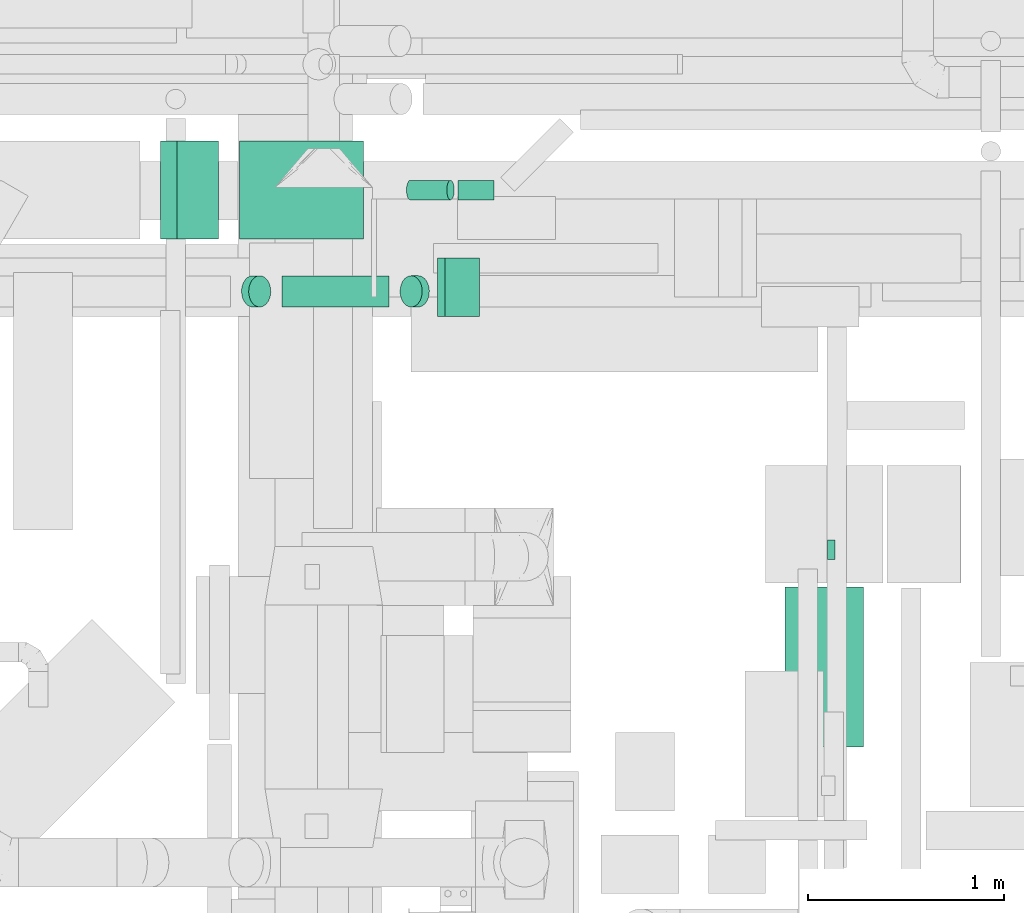
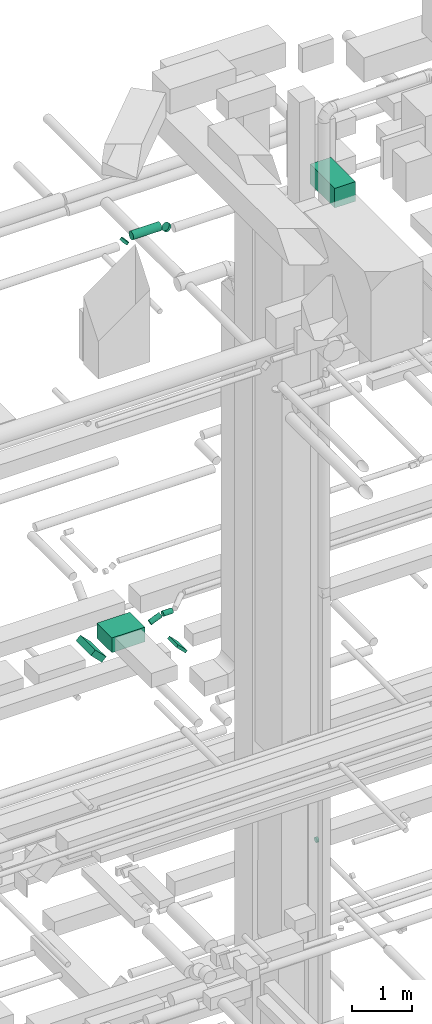
# One storey, part 134 of 337: 10 flow segments.
"""IFC2X3 building model written with IfcOpenShell, lengths in millimetres."""

from ifc_helpers import new_model, entity, si_unit, converted_unit, derived_unit, direction, frame, frame_2d, origin, origin_2d_with_axis, place, context, subcontext, project, spatial, rectangle, circle, extrude, type_object, element, save


model = new_model("IFC2X3")

# Units and contexts
model_context = context("Model", 3, precision=0.01, world=origin(), true_north=direction((6.12303176911189e-17, 1.0)))
body_context = subcontext(model_context, "Body", "Model", "MODEL_VIEW")
ifc_project = project(units=[si_unit("LENGTHUNIT", "METRE", prefix="MILLI"), si_unit("AREAUNIT", "SQUARE_METRE"), si_unit("VOLUMEUNIT", "CUBIC_METRE"), converted_unit("PLANEANGLEUNIT", "DEGREE", entity("IfcRatioMeasure", 0.0174532925199433), si_unit("PLANEANGLEUNIT", "RADIAN"), dimensions=[0, 0, 0, 0, 0, 0, 0]), si_unit("MASSUNIT", "GRAM", prefix="KILO"), derived_unit("MASSDENSITYUNIT", [(si_unit("MASSUNIT", "GRAM", prefix="KILO"), 1), (si_unit("LENGTHUNIT", "METRE"), -3)]), derived_unit("MOMENTOFINERTIAUNIT", [(si_unit("LENGTHUNIT", "METRE"), 4)]), si_unit("TIMEUNIT", "SECOND"), si_unit("FREQUENCYUNIT", "HERTZ"), si_unit("THERMODYNAMICTEMPERATUREUNIT", "DEGREE_CELSIUS"), derived_unit("THERMALTRANSMITTANCEUNIT", [(si_unit("MASSUNIT", "GRAM", prefix="KILO"), 1), (si_unit("THERMODYNAMICTEMPERATUREUNIT", "KELVIN"), -1), (si_unit("TIMEUNIT", "SECOND"), -3)]), derived_unit("VOLUMETRICFLOWRATEUNIT", [(si_unit("LENGTHUNIT", "METRE"), 3), (si_unit("TIMEUNIT", "SECOND"), -1)]), derived_unit("MASSFLOWRATEUNIT", [(si_unit("MASSUNIT", "GRAM", prefix="KILO"), 1), (si_unit("TIMEUNIT", "SECOND"), -1)]), derived_unit("ROTATIONALFREQUENCYUNIT", [(si_unit("TIMEUNIT", "SECOND"), -1)]), si_unit("ELECTRICCURRENTUNIT", "AMPERE"), si_unit("ELECTRICVOLTAGEUNIT", "VOLT"), si_unit("POWERUNIT", "WATT"), si_unit("FORCEUNIT", "NEWTON", prefix="KILO"), si_unit("ILLUMINANCEUNIT", "LUX"), si_unit("LUMINOUSFLUXUNIT", "LUMEN"), si_unit("LUMINOUSINTENSITYUNIT", "CANDELA"), derived_unit("USERDEFINED", [(si_unit("MASSUNIT", "GRAM", prefix="KILO"), -1), (si_unit("LENGTHUNIT", "METRE"), -2), (si_unit("TIMEUNIT", "SECOND"), 3), (si_unit("LUMINOUSFLUXUNIT", "LUMEN"), 1)]), derived_unit("LINEARVELOCITYUNIT", [(si_unit("LENGTHUNIT", "METRE"), 1), (si_unit("TIMEUNIT", "SECOND"), -1)]), si_unit("PRESSUREUNIT", "PASCAL"), derived_unit("USERDEFINED", [(si_unit("LENGTHUNIT", "METRE"), -2), (si_unit("MASSUNIT", "GRAM", prefix="KILO"), 1), (si_unit("TIMEUNIT", "SECOND"), -2)]), derived_unit("LINEARFORCEUNIT", [(si_unit("MASSUNIT", "GRAM", prefix="KILO"), 1), (si_unit("LENGTHUNIT", "METRE"), 1), (si_unit("TIMEUNIT", "SECOND"), -2), (si_unit("LENGTHUNIT", "METRE"), -1)]), derived_unit("PLANARFORCEUNIT", [(si_unit("MASSUNIT", "GRAM", prefix="KILO"), 1), (si_unit("LENGTHUNIT", "METRE"), 1), (si_unit("TIMEUNIT", "SECOND"), -2), (si_unit("LENGTHUNIT", "METRE"), -2)])], contexts=[model_context])

# Site, building, storey
site_placement = place(None, origin())
site = spatial("IfcSite", under=ifc_project, at=site_placement, CompositionType="ELEMENT")
building_placement = place(site_placement, origin())
building = spatial("IfcBuilding", under=site, at=building_placement, CompositionType="ELEMENT")
storey_placement = place(building_placement, origin())
storey = spatial("IfcBuildingStorey", under=building, at=storey_placement, CompositionType="ELEMENT", Elevation=0.0)

# Flow segments
duct_segment_type_1 = type_object("IfcDuctSegmentType", PredefinedType="NOTDEFINED")
flow_segment_1_placement = place(storey_placement, frame((22481.28, 14422.9, 18821.8)))
element("IfcFlowSegment", 1, at=flow_segment_1_placement, inside=storey, type_object=duct_segment_type_1, context=body_context, shape_type="SweptSolid", body=[
    extrude(rectangle(XDim=300.000000000002, YDim=119.166655855303, at=frame_2d((0.0, 0.0), x_axis=(0.0, 1.0))), frame((148.2, 0.0, 148.2), z_axis=(0.0, 1.0, 0.0), x_axis=(0.707106781186566, 0.0, 0.707106781186529)), (0.0, 0.0, 1.0), 500.000000000001),
])
flow_segment_2_placement = place(storey_placement, frame((22883.75, 14422.9, 18950.0)))
element("IfcFlowSegment", 2, at=flow_segment_2_placement, inside=storey, type_object=duct_segment_type_1, context=body_context, shape_type="SweptSolid", body=[
    extrude(rectangle(XDim=635.844695138277, YDim=500.000000000001, at=origin_2d_with_axis()), frame((317.92, 250.0, 0.0), z_axis=(0.0, 0.0, 1.0), x_axis=(-1.0, 0.0, 0.0)), (0.0, 0.0, 1.0), 300.000000000001),
])
flow_segment_3_placement = place(storey_placement, frame((23896.98, 14025.53, 18767.16)))
element("IfcFlowSegment", 3, at=flow_segment_3_placement, inside=storey, type_object=duct_segment_type_1, context=body_context, shape_type="SweptSolid", body=[
    extrude(rectangle(XDim=55.0252531694417, YDim=250.000000000006, at=origin_2d_with_axis()), frame((107.84, 0.0, 107.84), z_axis=(0.0, 1.0, 0.0), x_axis=(-0.707106781186351, 0.0, -0.707106781186744)), (0.0, 0.0, 1.0), 300.000000000001),
])
flow_segment_4_placement = place(storey_placement, frame((25675.03, 11824.99, 28600.0)))
element("IfcFlowSegment", 4, at=flow_segment_4_placement, inside=storey, type_object=duct_segment_type_1, context=body_context, shape_type="SweptSolid", body=[
    extrude(rectangle(XDim=819.604550000003, YDim=400.0, at=origin_2d_with_axis()), frame((200.0, 409.8, 0.0), z_axis=(0.0, 0.0, 1.0), x_axis=(0.0, 1.0, 0.0)), (0.0, 0.0, 1.0), 399.999999999996),
])
duct_segment_type_2 = type_object("IfcDuctSegmentType", PredefinedType="NOTDEFINED")
flow_segment_5_placement = place(storey_placement, frame((24002.01, 14621.3, 19148.91)))
element("IfcFlowSegment", 5, at=flow_segment_5_placement, inside=storey, type_object=duct_segment_type_2, context=body_context, shape_type="SweptSolid", body=[
    extrude(circle(Radius=50.0, at=origin_2d_with_axis()), frame((0.0, 51.6, 51.6), z_axis=(1.0, 0.0, 0.0), x_axis=(0.0, -1.0, 0.0)), (0.0, 0.0, 1.0), 184.090575000106),
])
flow_segment_6_placement = place(storey_placement, frame((23737.13, 14621.3, 19059.82)))
element("IfcFlowSegment", 6, at=flow_segment_6_placement, inside=storey, type_object=duct_segment_type_2, context=body_context, shape_type="SweptSolid", body=[
    extrude(circle(Radius=50.0, at=origin_2d_with_axis()), frame((20.73, 51.6, 47.79), z_axis=(0.923879536840847, 0.0, 0.382683421912608), x_axis=(0.0, -1.0, 0.0)), (0.0, 0.0, 1.0), 222.843292711526),
])
flow_segment_7_placement = place(storey_placement, frame((25890.75, 12782.72, 14998.4)))
element("IfcFlowSegment", 7, at=flow_segment_7_placement, inside=storey, type_object=duct_segment_type_2, context=body_context, shape_type="SweptSolid", body=[
    extrude(circle(Radius=50.0, at=origin_2d_with_axis()), frame((0.0, 51.6, 51.6), z_axis=(1.0, 0.0, 0.0), x_axis=(0.0, -1.0, 0.0)), (0.0, 0.0, 1.0), 40.0000000000299),
])
flow_segment_8_placement = place(storey_placement, frame((23101.41, 14073.37, 27448.4)))
element("IfcFlowSegment", 8, at=flow_segment_8_placement, inside=storey, type_object=duct_segment_type_2, context=body_context, shape_type="SweptSolid", body=[
    extrude(circle(Radius=80.0, at=origin_2d_with_axis()), frame((0.0, 81.6, 81.6), z_axis=(1.0, 0.0, 0.0), x_axis=(0.0, -1.0, 0.0)), (0.0, 0.0, 1.0), 548.01184948963),
])
flow_segment_9_placement = place(storey_placement, frame((22893.83, 14073.37, 27388.7)))
element("IfcFlowSegment", 9, at=flow_segment_9_placement, inside=storey, type_object=duct_segment_type_2, context=body_context, shape_type="SweptSolid", body=[
    extrude(circle(Radius=80.0, at=origin_2d_with_axis()), frame((58.16, 81.6, 58.16), z_axis=(0.70710662671088, 0.0, 0.707106935662182), x_axis=(0.0, -1.0, 0.0)), (0.0, 0.0, 1.0), 51.2993420344657),
])
flow_segment_10_placement = place(storey_placement, frame((23704.39, 14073.37, 27388.7)))
element("IfcFlowSegment", 10, at=flow_segment_10_placement, inside=storey, type_object=duct_segment_type_2, context=body_context, shape_type="SweptSolid", body=[
    extrude(circle(Radius=80.0, at=origin_2d_with_axis()), frame((58.16, 81.6, 94.44), z_axis=(0.70710662671088, 0.0, -0.707106935662182), x_axis=(0.0, 1.0, 0.0)), (0.0, 0.0, 1.0), 51.2993420344657),
])

save(model, "model.ifc")
